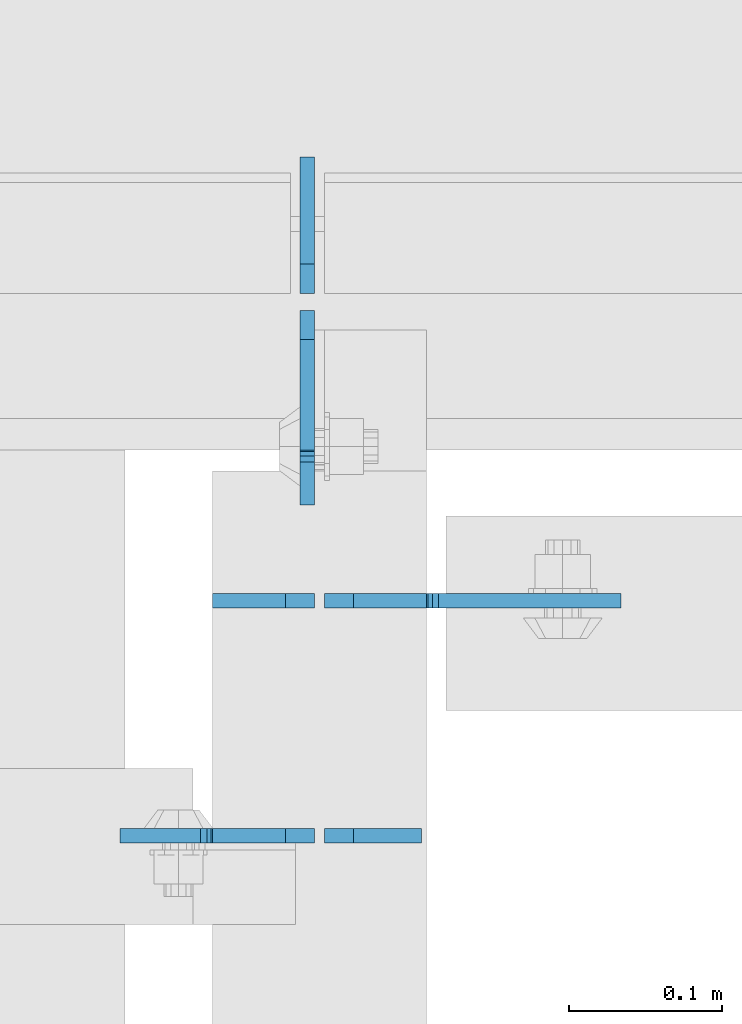
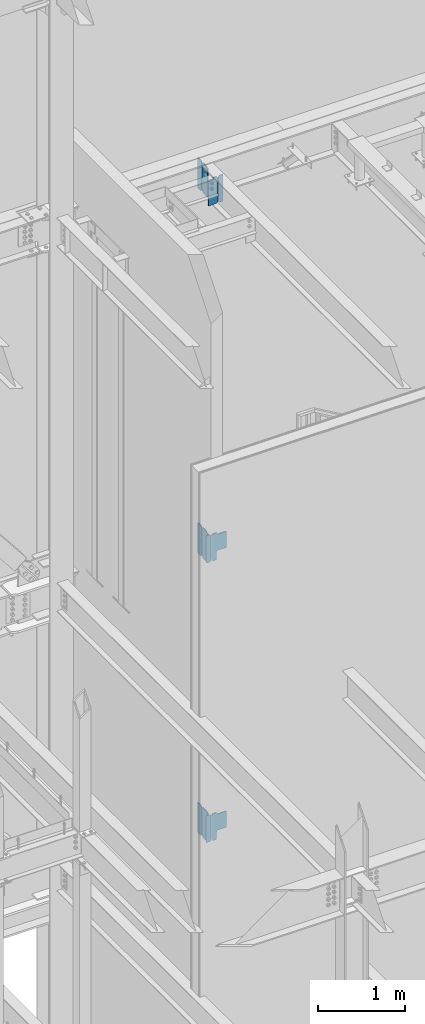
# One storey, part 1111 of 1179: 12 plates, 6 elements without a shape of their own.
"""IFC2X3 building model written with IfcOpenShell, lengths in millimetres."""

from ifc_helpers import new_model, si_unit, frame, origin_with_axes, place, context, subcontext, project, spatial, faceted_brep, material, type_object, element, aggregate, save


model = new_model("IFC2X3")

# Units and contexts
model_context = context("Model", 3, precision=1e-05, world=origin_with_axes())
body_context = subcontext(model_context, "Body", "Model", "MODEL_VIEW")
ifc_project = project(units=[si_unit("LENGTHUNIT", "METRE", prefix="MILLI"), si_unit("AREAUNIT", "SQUARE_METRE"), si_unit("VOLUMEUNIT", "CUBIC_METRE"), si_unit("MASSUNIT", "GRAM", prefix="KILO"), si_unit("TIMEUNIT", "SECOND"), si_unit("PLANEANGLEUNIT", "RADIAN"), si_unit("SOLIDANGLEUNIT", "STERADIAN"), si_unit("THERMODYNAMICTEMPERATUREUNIT", "DEGREE_CELSIUS"), si_unit("LUMINOUSINTENSITYUNIT", "LUMEN")], contexts=[model_context])

# Site, building, storey
site_placement = place(None, origin_with_axes())
site = spatial("IfcSite", under=ifc_project, at=site_placement, CompositionType="ELEMENT")
building_placement = place(site_placement, origin_with_axes())
building = spatial("IfcBuilding", under=site, at=building_placement, Name="Undefined", CompositionType="ELEMENT")
storey_placement = place(building_placement, origin_with_axes())
storey = spatial("IfcBuildingStorey", under=building, at=storey_placement, Name="Undefined", CompositionType="ELEMENT", Elevation=0.0)

# Assembly, plate
assembly_1_placement = place(storey_placement, origin_with_axes())
assembly_1 = element("IfcElementAssembly", 1, at=assembly_1_placement, inside=storey, Name="BEAM", AssemblyPlace="NOTDEFINED", PredefinedType="RIGID_FRAME")
ifc_material = material(Name="STEEL/A36")
plate_type_1 = type_object("IfcPlateType", PredefinedType="NOTDEFINED")
plate_1_placement = place(assembly_1_placement, frame((18411.825, 40850.3442499161, 12728.575), z_axis=(0.0, 0.0, 1.0), x_axis=(-1.0, 0.0, 0.0)))
plate_1 = element("IfcPlate", 2, at=plate_1_placement, type_object=plate_type_1, material=ifc_material, Name="PLATE", context=body_context, shape_type="Brep", body=[
    faceted_brep([(66.6749998164378, -4.76249999999709, 377.825), (66.6749999434469, -4.76249999999709, 371.474999553748), (66.6749999434469, 4.76249999999709, 371.474999553748), (66.6749998164378, 4.76249999999709, 377.825), (67.641729938794, -4.76249999999709, 366.614920114053), (67.641729938794, 4.76249999999709, 366.614920114053), (70.394743855788, -4.76249999999709, 362.494743732281), (70.394743855788, 4.76249999999709, 362.494743732281), (74.5149202922948, -4.76249999999709, 359.741729897201), (74.5149202922948, 4.76249999999709, 359.741729897201), (79.3749997512095, -4.76249999999709, 358.774999998475), (79.3749997512095, 4.76249999999709, 358.774999998475), (127.000000004868, -4.76249999999709, 358.774999992755), (127.0, 4.76249999999709, 358.774999992755), (0.0, -4.76249999999709, 358.775000762939), (19.0499992370605, -4.76249999999709, 377.825), (19.0499992370605, 4.76249999999709, 377.825), (0.0, 4.76249999999709, 358.775000762939), (0.0, -4.76250000000073, 19.0499992370605), (0.0, 4.76250000000073, 19.0499992370605), (19.0499992370605, -4.76250000000073, 0.0), (19.0499992370605, 4.76250000000073, 0.0), (127.0, -4.76250000000073, 0.0), (127.0, 4.76250000000073, 0.0)], [[[0, 1, 2, 3]], [[4, 5, 2, 1]], [[6, 7, 5, 4]], [[8, 9, 7, 6]], [[10, 11, 9, 8]], [[12, 13, 11, 10]], [[14, 15, 16, 17]], [[18, 14, 17, 19]], [[20, 18, 19, 21]], [[22, 20, 21, 23]], [[8, 6, 4, 1, 0, 15, 14, 18, 20, 22, 12, 10]], [[16, 15, 0, 3]], [[23, 21, 19, 17, 16, 3, 2, 5, 7, 9, 11, 13]], [[22, 23, 13, 12]]]),
])

assembly_2_placement = place(storey_placement, origin_with_axes())
assembly_2 = element("IfcElementAssembly", 3, at=assembly_2_placement, inside=storey, Name="BEAM", AssemblyPlace="NOTDEFINED", PredefinedType="RIGID_FRAME")
plate_2_placement = place(assembly_2_placement, frame((18407.0620000839, 41193.24375, 12673.0125), z_axis=(0.0, 0.0, 1.0), x_axis=(0.0, -1.0, 0.0)))
plate_2 = element("IfcPlate", 4, at=plate_2_placement, type_object=plate_type_1, material=ifc_material, Name="PLATE", context=body_context, shape_type="Brep", body=[
    faceted_brep([(91.28125, -4.76250000000073, 425.450000000001), (91.28125, -4.76250000000073, 420.687499809264), (91.28125, 4.76250000000073, 420.687499809264), (91.28125, 4.76250000000073, 425.450000000001), (92.2479799225912, -4.76250000000073, 415.827420291219), (92.2479799225912, 4.76250000000073, 415.827420291219), (95.0009938230651, -4.76250000000073, 411.707243823065), (95.0009938230651, 4.76250000000073, 411.707243823065), (99.1211702912187, -4.76250000000073, 408.954229922587), (99.1211702912187, 4.76250000000073, 408.954229922587), (103.981249809265, -4.76250000000073, 407.987499999999), (103.981249809265, 4.76250000000073, 407.987499999999), (126.999999992826, -4.76249999999709, 407.9875), (127.0, 4.76249999999709, 407.9875), (0.0, -4.76249999999709, 406.400000762939), (19.0499992370605, -4.76249999999709, 425.45), (19.0499992370605, 4.76249999999709, 425.45), (0.0, 4.76249999999709, 406.400000762939), (0.0, -4.76250000000073, 19.0499992370605), (0.0, 4.76250000000073, 19.0499992370605), (19.0499992370605, -4.76250000000073, 0.0), (19.0499992370605, 4.76250000000073, 0.0), (127.0, -4.76250000000073, 0.0), (127.0, 4.76250000000073, 0.0)], [[[0, 1, 2, 3]], [[4, 5, 2, 1]], [[6, 7, 5, 4]], [[8, 9, 7, 6]], [[10, 11, 9, 8]], [[12, 13, 11, 10]], [[14, 15, 16, 17]], [[18, 14, 17, 19]], [[20, 18, 19, 21]], [[22, 20, 21, 23]], [[8, 6, 4, 1, 0, 15, 14, 18, 20, 22, 12, 10]], [[16, 15, 0, 3]], [[23, 21, 19, 17, 16, 3, 2, 5, 7, 9, 11, 13]], [[22, 23, 13, 12]]]),
])

assembly_3_placement = place(storey_placement, origin_with_axes())
assembly_3 = element("IfcElementAssembly", 5, at=assembly_3_placement, inside=storey, Name="BEAM", AssemblyPlace="NOTDEFINED", PredefinedType="RIGID_FRAME")
plate_3_placement = place(assembly_3_placement, frame((18407.0620000839, 41193.24375, 7567.6125), z_axis=(0.0, 0.0, 1.0), x_axis=(0.0, -1.0, 0.0)))
plate_3 = element("IfcPlate", 6, at=plate_3_placement, type_object=plate_type_1, material=ifc_material, Name="PLATE", context=body_context, shape_type="Brep", body=[
    faceted_brep([(91.28125, -4.76250000000073, 425.450000000001), (91.28125, -4.76250000000073, 420.687499809264), (91.28125, 4.76250000000073, 420.687499809264), (91.28125, 4.76250000000073, 425.450000000001), (92.2479799225912, -4.76250000000073, 415.827420291219), (92.2479799225912, 4.76250000000073, 415.827420291219), (95.0009938230651, -4.76250000000073, 411.707243823065), (95.0009938230651, 4.76250000000073, 411.707243823065), (99.1211702912187, -4.76250000000073, 408.954229922587), (99.1211702912187, 4.76250000000073, 408.954229922587), (103.981249809265, -4.76250000000073, 407.987499999999), (103.981249809265, 4.76250000000073, 407.987499999999), (126.999999992826, -4.76249999999709, 407.9875), (127.0, 4.76249999999709, 407.9875), (0.0, -4.76249999999709, 406.400000762939), (19.0499992370605, -4.76249999999709, 425.45), (19.0499992370605, 4.76249999999709, 425.45), (0.0, 4.76249999999709, 406.400000762939), (0.0, -4.76250000000073, 19.0499992370605), (0.0, 4.76250000000073, 19.0499992370605), (19.0499992370605, -4.76250000000073, 0.0), (19.0499992370605, 4.76250000000073, 0.0), (127.0, -4.76250000000073, 0.0), (127.0, 4.76250000000073, 0.0)], [[[0, 1, 2, 3]], [[4, 5, 2, 1]], [[6, 7, 5, 4]], [[8, 9, 7, 6]], [[10, 11, 9, 8]], [[12, 13, 11, 10]], [[14, 15, 16, 17]], [[18, 14, 17, 19]], [[20, 18, 19, 21]], [[22, 20, 21, 23]], [[8, 6, 4, 1, 0, 15, 14, 18, 20, 22, 12, 10]], [[16, 15, 0, 3]], [[23, 21, 19, 17, 16, 3, 2, 5, 7, 9, 11, 13]], [[22, 23, 13, 12]]]),
])

assembly_4_placement = place(storey_placement, origin_with_axes())
assembly_4 = element("IfcElementAssembly", 7, at=assembly_4_placement, inside=storey, Name="BEAM", AssemblyPlace="NOTDEFINED", PredefinedType="RIGID_FRAME")
plate_4_placement = place(assembly_4_placement, frame((18407.0620000839, 41193.24375, 3656.0125), z_axis=(0.0, 0.0, 1.0), x_axis=(0.0, -1.0, 0.0)))
plate_4 = element("IfcPlate", 8, at=plate_4_placement, type_object=plate_type_1, material=ifc_material, Name="PLATE", context=body_context, shape_type="Brep", body=[
    faceted_brep([(92.2477129146355, -4.76249999998981, 422.177283577026), (92.2477129146355, 4.76250000000073, 422.177283577026), (91.5968258937282, 4.76250000000073, 425.45), (91.5968258937282, -4.76250000000073, 425.45), (95.0006809698098, -4.76249999998981, 418.057128901527), (95.0006809698098, 4.76250000000073, 418.057128901527), (99.1207971084514, -4.76249999998981, 415.304103172084), (99.1207971084514, 4.76250000000073, 415.304103172084), (103.980822032783, -4.76249999998981, 414.337322226008), (103.980822032783, 4.76250000000073, 414.337322226008), (127.000007629402, -4.76249999998981, 414.337000000034), (127.0, 4.76250000000073, 414.337000000034), (0.0, -4.76249999999709, 406.400000762939), (19.0499992370605, -4.76249999999709, 425.45), (19.0499992370605, 4.76249999999709, 425.45), (0.0, 4.76249999999709, 406.400000762939), (0.0, -4.76250000000073, 19.0499992370605), (0.0, 4.76250000000073, 19.0499992370605), (19.0499992370605, -4.76250000000073, 0.0), (19.0499992370605, 4.76250000000073, 0.0), (127.0, -4.76250000000073, 0.0), (127.0, 4.76250000000073, 0.0)], [[[0, 1, 2, 3]], [[4, 5, 1, 0]], [[6, 7, 5, 4]], [[8, 9, 7, 6]], [[10, 11, 9, 8]], [[12, 13, 14, 15]], [[16, 12, 15, 17]], [[18, 16, 17, 19]], [[20, 18, 19, 21]], [[6, 4, 0, 3, 13, 12, 16, 18, 20, 10, 8]], [[14, 13, 3, 2]], [[21, 19, 17, 15, 14, 2, 1, 5, 7, 9, 11]], [[20, 21, 11, 10]]]),
])

# Plate
plate_type_2 = type_object("IfcPlateType", PredefinedType="NOTDEFINED")
plate_5_placement = place(assembly_2_placement, frame((18407.0620000839, 41204.35625, 12673.0125), z_axis=(0.0, 0.0, 1.0), x_axis=(0.0, 1.0, 0.0)))
plate_5 = element("IfcPlate", 9, at=plate_5_placement, type_object=plate_type_2, material=ifc_material, Name="PLATE", context=body_context, shape_type="Brep", body=[
    faceted_brep([(0.0, -4.76250000000073, 19.0499992370605), (0.0, -4.76249999999709, 406.400000762939), (0.0, 4.76249999999709, 406.400000762939), (0.0, 4.76250000000073, 19.0499992370605), (19.0499992370605, -4.76249999999709, 425.45), (19.0499992370605, 4.76249999999709, 425.45), (88.9000015258789, -4.76250000000073, 425.450012207031), (88.9000015258789, 4.76250000000073, 425.450012207031), (88.8999999999996, -4.76250000000005, 0.0), (88.8999999999996, 4.76250000000005, 0.0), (19.0499992370605, -4.76250000000073, 0.0), (19.0499992370605, 4.76250000000073, 0.0)], [[[0, 1, 2, 3]], [[1, 4, 5, 2]], [[4, 6, 7, 5]], [[6, 8, 9, 7]], [[8, 10, 11, 9]], [[10, 0, 3, 11]], [[5, 7, 9, 11, 3, 2]], [[10, 8, 6, 4, 1, 0]]]),
])

aggregate(assembly_2, [plate_5, plate_2])

plate_6_placement = place(assembly_3_placement, frame((18407.0620000839, 41204.35625, 7567.6125), z_axis=(0.0, 0.0, 1.0), x_axis=(0.0, 1.0, 0.0)))
plate_6 = element("IfcPlate", 10, at=plate_6_placement, type_object=plate_type_2, material=ifc_material, Name="PLATE", context=body_context, shape_type="Brep", body=[
    faceted_brep([(0.0, -4.76250000000073, 19.0499992370605), (0.0, -4.76249999999709, 406.400000762939), (0.0, 4.76249999999709, 406.400000762939), (0.0, 4.76250000000073, 19.0499992370605), (19.0499992370605, -4.76249999999709, 425.45), (19.0499992370605, 4.76249999999709, 425.45), (88.9000015258789, -4.76250000000073, 425.450012207031), (88.9000015258789, 4.76250000000073, 425.450012207031), (88.8999999999996, -4.76250000000005, 0.0), (88.8999999999996, 4.76250000000005, 0.0), (19.0499992370605, -4.76250000000073, 0.0), (19.0499992370605, 4.76250000000073, 0.0)], [[[0, 1, 2, 3]], [[1, 4, 5, 2]], [[4, 6, 7, 5]], [[6, 8, 9, 7]], [[8, 10, 11, 9]], [[10, 0, 3, 11]], [[5, 7, 9, 11, 3, 2]], [[10, 8, 6, 4, 1, 0]]]),
])

aggregate(assembly_3, [plate_6, plate_3])

plate_7_placement = place(assembly_4_placement, frame((18407.0620000839, 41204.35625, 3656.0125), z_axis=(0.0, 0.0, 1.0), x_axis=(0.0, 1.0, 0.0)))
plate_7 = element("IfcPlate", 11, at=plate_7_placement, type_object=plate_type_2, material=ifc_material, Name="PLATE", context=body_context, shape_type="Brep", body=[
    faceted_brep([(0.0, -4.76250000000073, 19.0499992370605), (0.0, -4.76249999999709, 406.400000762939), (0.0, 4.76249999999709, 406.400000762939), (0.0, 4.76250000000073, 19.0499992370605), (19.0499992370605, -4.76249999999709, 425.45), (19.0499992370605, 4.76249999999709, 425.45), (88.9000015258789, -4.76250000000073, 425.450012207031), (88.9000015258789, 4.76250000000073, 425.450012207031), (88.8999999999996, -4.76250000000005, 0.0), (88.8999999999996, 4.76250000000005, 0.0), (19.0499992370605, -4.76250000000073, 0.0), (19.0499992370605, 4.76250000000073, 0.0)], [[[0, 1, 2, 3]], [[1, 4, 5, 2]], [[4, 6, 7, 5]], [[6, 8, 9, 7]], [[8, 10, 11, 9]], [[10, 0, 3, 11]], [[5, 7, 9, 11, 3, 2]], [[10, 8, 6, 4, 1, 0]]]),
])

aggregate(assembly_4, [plate_7, plate_4])

# Assembly, plate
assembly_5_placement = place(storey_placement, origin_with_axes())
assembly_5 = element("IfcElementAssembly", 12, at=assembly_5_placement, inside=storey, Name="BEAM", AssemblyPlace="NOTDEFINED", PredefinedType="RIGID_FRAME")
plate_type_3 = type_object("IfcPlateType", PredefinedType="NOTDEFINED")
plate_8_placement = place(assembly_5_placement, frame((18411.825, 41003.5379999842, 3711.575), z_axis=(0.0, 0.0, 1.0), x_axis=(-1.0, 0.0, 0.0)))
plate_8 = element("IfcPlate", 13, at=plate_8_placement, type_object=plate_type_3, material=ifc_material, Name="PLATE", context=body_context, shape_type="Brep", body=[
    faceted_brep([(0.0, -4.76250000000073, 19.0499992370605), (0.0, -4.76249999999709, 358.775000762939), (0.0, 4.76249999999709, 358.775000762939), (0.0, 4.76250000000073, 19.0499992370605), (19.0499992370605, -4.76249999999709, 377.825), (19.0499992370605, 4.76249999999709, 377.825), (66.6749386683441, -4.76249999999709, 377.825), (66.6749386683441, 4.76249999999709, 377.825), (66.6749386683441, -4.76249999999709, 0.0), (66.6749386683441, 4.76249999999709, 0.0), (19.0499992370605, -4.76250000000073, 0.0), (19.0499992370605, 4.76250000000073, 0.0)], [[[0, 1, 2, 3]], [[1, 4, 5, 2]], [[4, 6, 7, 5]], [[6, 8, 9, 7]], [[8, 10, 11, 9]], [[10, 0, 3, 11]], [[5, 7, 9, 11, 3, 2]], [[10, 8, 6, 4, 1, 0]]]),
])

assembly_6_placement = place(storey_placement, origin_with_axes())
assembly_6 = element("IfcElementAssembly", 14, at=assembly_6_placement, inside=storey, Name="BEAM", AssemblyPlace="NOTDEFINED", PredefinedType="RIGID_FRAME")
plate_9_placement = place(assembly_6_placement, frame((18411.825, 41003.5379998964, 7623.175), z_axis=(0.0, 0.0, 1.0), x_axis=(-1.0, 0.0, 0.0)))
plate_9 = element("IfcPlate", 15, at=plate_9_placement, type_object=plate_type_3, material=ifc_material, Name="PLATE", context=body_context, shape_type="Brep", body=[
    faceted_brep([(0.0, -4.76250000000073, 19.0499992370605), (0.0, -4.76249999999709, 358.775000762939), (0.0, 4.76249999999709, 358.775000762939), (0.0, 4.76250000000073, 19.0499992370605), (19.0499992370605, -4.76249999999709, 377.825), (19.0499992370605, 4.76249999999709, 377.825), (66.6749386683441, -4.76249999999709, 377.825), (66.6749386683441, 4.76249999999709, 377.825), (66.6749386683441, -4.76249999999709, 0.0), (66.6749386683441, 4.76249999999709, 0.0), (19.0499992370605, -4.76250000000073, 0.0), (19.0499992370605, 4.76250000000073, 0.0)], [[[0, 1, 2, 3]], [[1, 4, 5, 2]], [[4, 6, 7, 5]], [[6, 8, 9, 7]], [[8, 10, 11, 9]], [[10, 0, 3, 11]], [[5, 7, 9, 11, 3, 2]], [[10, 8, 6, 4, 1, 0]]]),
])

# Plate
plate_type_4 = type_object("IfcPlateType", PredefinedType="NOTDEFINED")
plate_10_placement = place(assembly_5_placement, frame((18418.175, 41003.5379999842, 3730.625), z_axis=(0.707106781186573, 0.0, 0.707106781186522), x_axis=(0.707106781186522, 0.0, -0.707106781186573)))
plate_10 = element("IfcPlate", 16, at=plate_10_placement, type_object=plate_type_4, material=ifc_material, Name="PLATE", context=body_context, shape_type="Brep", body=[
    faceted_brep([(0.0, -4.76249999999709, 0.0), (-240.221851238686, -4.76249999999709, 240.221851238675), (-240.221851238686, 4.76249999999709, 240.221851238675), (0.0, 4.76249999999709, 0.0), (-240.221851238757, -4.76249999999709, 267.162619601822), (-240.221851238757, 4.76249999999709, 267.162619601822), (-206.545890784913, -4.76249999999709, 300.838580055672), (-206.545890784913, 4.76249999999709, 300.838580055672), (-197.56563452897, -4.76249999999709, 291.858323799728), (-197.56563452897, 4.76249999999709, 291.858323799728), (-193.445458060814, -4.76249999999709, 289.105309899251), (-193.445458060814, 4.76249999999709, 289.105309899251), (-188.585378542773, -4.76249999999709, 288.138579976656), (-188.585378542773, 4.76249999999709, 288.138579976656), (-183.725299024736, -4.76249999999709, 289.105309899236), (-183.725299024736, 4.76249999999709, 289.105309899236), (-179.605122556588, -4.76249999999709, 291.858323799706), (-179.605122556588, 4.76249999999709, 291.858323799706), (-98.7828173325106, -4.76249999999709, 372.680629023791), (-98.7828173325106, 4.76249999999709, 372.680629023791), (62.8617928467938, -4.76249999999709, 211.036018844497), (62.8617928467938, 4.76249999999709, 211.036018844497), (-17.9605123772835, -4.76249999999709, 130.213713620413), (-17.9605123772835, 4.76249999999709, 130.213713620413), (-20.7135262777556, -4.76249999999709, 126.093537152266), (-20.7135262777556, 4.76249999999709, 126.093537152266), (-21.680256200334, -4.76249999999709, 121.233457634227), (-21.680256200334, 4.76249999999709, 121.233457634227), (-20.713526277741, -4.76249999999709, 116.373378116188), (-20.713526277741, 4.76249999999709, 116.373378116188), (-17.9605123772617, -4.76249999999709, 112.253201648035), (-17.9605123772617, 4.76249999999709, 112.253201648035), (60.6167288169963, -4.76249999999709, 33.675960453782), (60.6167288169963, 4.76249999999709, 33.675960453782), (26.9407683631525, -4.76249999999709, -6.18456397205591e-11), (26.9407683631525, 4.76249999999709, -6.18456397205591e-11)], [[[0, 1, 2, 3]], [[1, 4, 5, 2]], [[4, 6, 7, 5]], [[6, 8, 9, 7]], [[8, 10, 11, 9]], [[10, 12, 13, 11]], [[12, 14, 15, 13]], [[14, 16, 17, 15]], [[16, 18, 19, 17]], [[18, 20, 21, 19]], [[20, 22, 23, 21]], [[22, 24, 25, 23]], [[24, 26, 27, 25]], [[26, 28, 29, 27]], [[28, 30, 31, 29]], [[30, 32, 33, 31]], [[32, 34, 35, 33]], [[34, 0, 3, 35]], [[5, 7, 9, 11, 13, 15, 17, 19, 21, 23, 25, 27, 29, 31, 33, 35, 3, 2]], [[34, 32, 30, 28, 26, 24, 22, 20, 18, 16, 14, 12, 10, 8, 6, 4, 1, 0]]]),
])

aggregate(assembly_5, [plate_8, plate_10])

plate_11_placement = place(assembly_6_placement, frame((18418.175, 41003.5379998964, 7642.225), z_axis=(0.707106781186573, 0.0, 0.707106781186522), x_axis=(0.707106781186522, 0.0, -0.707106781186573)))
plate_11 = element("IfcPlate", 17, at=plate_11_placement, type_object=plate_type_4, material=ifc_material, Name="PLATE", context=body_context, shape_type="Brep", body=[
    faceted_brep([(0.0, -4.76249999999709, 0.0), (-240.221851238686, -4.76249999999709, 240.221851238675), (-240.221851238686, 4.76249999999709, 240.221851238675), (0.0, 4.76249999999709, 0.0), (-240.221851238757, -4.76249999999709, 267.162619601822), (-240.221851238757, 4.76249999999709, 267.162619601822), (-206.545890784913, -4.76249999999709, 300.838580055672), (-206.545890784913, 4.76249999999709, 300.838580055672), (-197.56563452897, -4.76249999999709, 291.858323799728), (-197.56563452897, 4.76249999999709, 291.858323799728), (-193.445458060814, -4.76249999999709, 289.105309899251), (-193.445458060814, 4.76249999999709, 289.105309899251), (-188.585378542773, -4.76249999999709, 288.138579976656), (-188.585378542773, 4.76249999999709, 288.138579976656), (-183.725299024736, -4.76249999999709, 289.105309899236), (-183.725299024736, 4.76249999999709, 289.105309899236), (-179.605122556588, -4.76249999999709, 291.858323799706), (-179.605122556588, 4.76249999999709, 291.858323799706), (-98.7828173325106, -4.76249999999709, 372.680629023791), (-98.7828173325106, 4.76249999999709, 372.680629023791), (62.8617928467938, -4.76249999999709, 211.036018844497), (62.8617928467938, 4.76249999999709, 211.036018844497), (-17.9605123772835, -4.76249999999709, 130.213713620413), (-17.9605123772835, 4.76249999999709, 130.213713620413), (-20.7135262777556, -4.76249999999709, 126.093537152266), (-20.7135262777556, 4.76249999999709, 126.093537152266), (-21.680256200334, -4.76249999999709, 121.233457634227), (-21.680256200334, 4.76249999999709, 121.233457634227), (-20.713526277741, -4.76249999999709, 116.373378116188), (-20.713526277741, 4.76249999999709, 116.373378116188), (-17.9605123772617, -4.76249999999709, 112.253201648035), (-17.9605123772617, 4.76249999999709, 112.253201648035), (60.6167288169963, -4.76249999999709, 33.675960453782), (60.6167288169963, 4.76249999999709, 33.675960453782), (26.9407683631525, -4.76249999999709, -6.18456397205591e-11), (26.9407683631525, 4.76249999999709, -6.18456397205591e-11)], [[[0, 1, 2, 3]], [[1, 4, 5, 2]], [[4, 6, 7, 5]], [[6, 8, 9, 7]], [[8, 10, 11, 9]], [[10, 12, 13, 11]], [[12, 14, 15, 13]], [[14, 16, 17, 15]], [[16, 18, 19, 17]], [[18, 20, 21, 19]], [[20, 22, 23, 21]], [[22, 24, 25, 23]], [[24, 26, 27, 25]], [[26, 28, 29, 27]], [[28, 30, 31, 29]], [[30, 32, 33, 31]], [[32, 34, 35, 33]], [[34, 0, 3, 35]], [[5, 7, 9, 11, 13, 15, 17, 19, 21, 23, 25, 27, 29, 31, 33, 35, 3, 2]], [[34, 32, 30, 28, 26, 24, 22, 20, 18, 16, 14, 12, 10, 8, 6, 4, 1, 0]]]),
])

aggregate(assembly_6, [plate_9, plate_11])

plate_type_5 = type_object("IfcPlateType", PredefinedType="NOTDEFINED")
plate_12_placement = place(assembly_1_placement, frame((18418.175, 40850.3442499161, 12728.575), z_axis=(0.0, 0.0, 1.0), x_axis=(1.0, 0.0, 0.0)))
plate_12 = element("IfcPlate", 18, at=plate_12_placement, type_object=plate_type_5, material=ifc_material, Name="PLATE", context=body_context, shape_type="Brep", body=[
    faceted_brep([(0.0, -4.76250000000073, 19.0499992370605), (0.0, -4.76249999999709, 358.775000762939), (0.0, 4.76249999999709, 358.775000762939), (0.0, 4.76250000000073, 19.0499992370605), (19.0499992370605, -4.76249999999709, 377.825), (19.0499992370605, 4.76249999999709, 377.825), (63.5, -4.76250000000073, 377.825012207031), (63.5, 4.76250000000073, 377.825012207031), (63.5, -4.76250000000073, 0.0), (63.5, 4.76250000000073, 0.0), (19.0499992370605, -4.76250000000073, 0.0), (19.0499992370605, 4.76250000000073, 0.0)], [[[0, 1, 2, 3]], [[1, 4, 5, 2]], [[4, 6, 7, 5]], [[6, 8, 9, 7]], [[8, 10, 11, 9]], [[10, 0, 3, 11]], [[5, 7, 9, 11, 3, 2]], [[10, 8, 6, 4, 1, 0]]]),
])

aggregate(assembly_1, [plate_12, plate_1])

save(model, "model.ifc")
